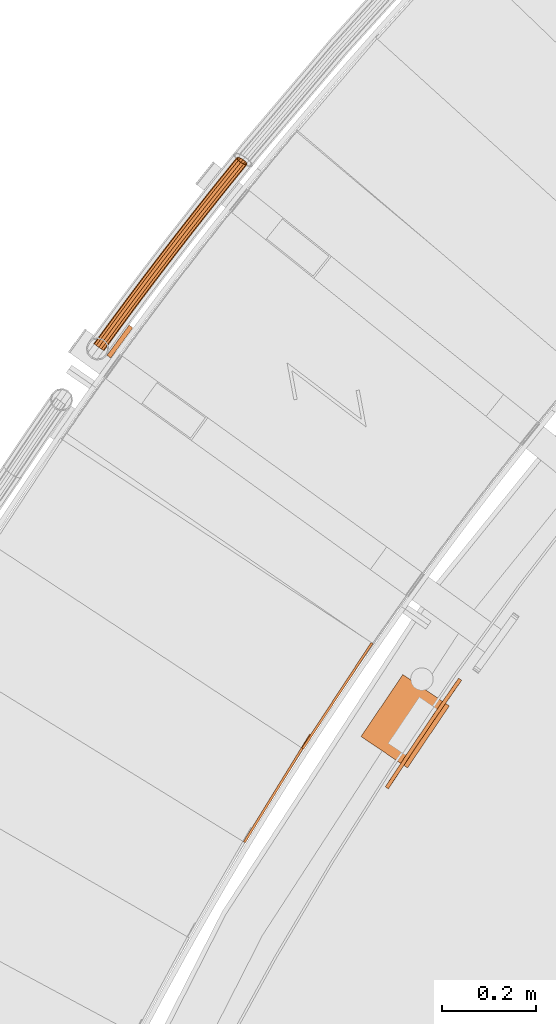
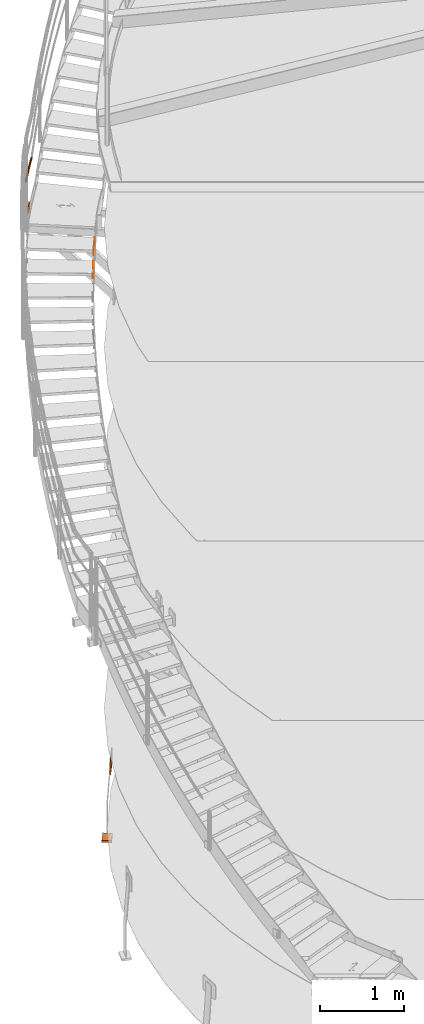
# One storey, part 67 of 126: 6 proxies.
"""IFC2X3 building model written with IfcOpenShell, lengths in millimetres."""

from ifc_helpers import new_model, si_unit, origin, origin_with_axes, place, context, project, spatial, faceted_brep, material, element, save


model = new_model("IFC2X3")

# Units and contexts
context_of_model_1 = context(None, 3, precision=0.1, world=origin())
context_of_model_2 = context(None, 3, precision=0.1, world=origin())
ifc_project = project(units=[si_unit("LENGTHUNIT", "METRE", prefix="MILLI"), si_unit("AREAUNIT", "SQUARE_METRE", prefix="CENTI"), si_unit("VOLUMEUNIT", "CUBIC_METRE", prefix="CENTI"), si_unit("MASSUNIT", "GRAM", prefix="KILO")], contexts=[context_of_model_1, context_of_model_2])

# Site, building, storey
site_placement = place(None, origin_with_axes())
site = spatial("IfcSite", under=ifc_project, at=site_placement, CompositionType="ELEMENT")
building_placement = place(site_placement, origin_with_axes())
building = spatial("IfcBuilding", under=site, at=building_placement, CompositionType="ELEMENT")
storey_placement = place(building_placement, origin_with_axes())
storey = spatial("IfcBuildingStorey", under=building, at=storey_placement, CompositionType="ELEMENT")

# Proxies
ifc_material_1 = material(Name="S235JRG2")
proxy_1_placement = place(storey_placement, origin_with_axes())
element("IfcBuildingElementProxy", 1, at=proxy_1_placement, inside=storey, material=ifc_material_1, context=context_of_model_2, shape_type="Brep", body=[
    faceted_brep([(1135.4304, 12147.675, 7896.89), (1139.6883, 12145.054, 7896.89), (1139.6883, 12145.054, 7966.89), (1135.4304, 12147.675, 7966.89), (1276.9731, 12377.6, 7966.89), (1281.231, 12374.979, 7966.89), (1281.231, 12374.979, 7926.89), (1276.9731, 12377.6, 7926.89), (1261.2462, 12352.053, 7896.89), (1265.504, 12349.432, 7896.89)], [[[0, 1, 2, 3]], [[4, 5, 6, 7]], [[0, 8, 9, 1]], [[1, 9, 6, 5, 2]], [[2, 5, 4, 3]], [[0, 3, 4, 7, 8]], [[6, 9, 8, 7]]]),
])
proxy_2_placement = place(storey_placement, origin_with_axes())
element("IfcBuildingElementProxy", 2, at=proxy_2_placement, inside=storey, material=ifc_material_1, context=context_of_model_2, shape_type="Brep", body=[
    faceted_brep([(1260.3402, 12348.075, 8070.05), (1264.5191, 12345.33, 8070.05), (1264.5191, 12345.33, 8140.05), (1260.3402, 12348.075, 8140.05), (1408.5891, 12573.735, 8140.05), (1412.768, 12570.99, 8140.05), (1412.768, 12570.99, 8100.05), (1408.5891, 12573.735, 8100.05), (1392.117, 12548.662, 8070.05), (1396.2959, 12545.916, 8070.05)], [[[0, 1, 2, 3]], [[4, 5, 6, 7]], [[0, 8, 9, 1]], [[1, 9, 6, 5, 2]], [[2, 5, 4, 3]], [[0, 3, 4, 7, 8]], [[6, 9, 8, 7]]]),
])
ifc_material_2 = material(Name="STAHL")
proxy_3_placement = place(storey_placement, origin_with_axes())
element("IfcBuildingElementProxy", 3, at=proxy_3_placement, inside=storey, material=ifc_material_2, Name="profile", context=context_of_model_2, shape_type="Brep", body=[
    faceted_brep([(1594.8, 12481.9, 704.7), (1597.2, 12485.4, 701.2), (1590.7, 12490.0, 701.2), (1588.0, 12486.1, 705.1), (1592.0, 12477.9, 707.5), (1584.8, 12481.6, 707.9), (1588.6, 12473.0, 709.4), (1581.7, 12477.1, 709.5), (1459.0, 12280.9, 709.5), (1462.0, 12285.5, 710.0), (1502.5, 12346.8, 710.0), (1543.5, 12407.6, 710.0), (1585.1, 12468.0, 710.0), (1578.6, 12472.6, 710.0), (1536.9, 12412.1, 710.0), (1495.8, 12351.2, 710.0), (1455.3, 12289.9, 710.0), (1452.0, 12284.8, 709.4), (1448.5, 12264.8, 697.0), (1450.4, 12267.8, 701.2), (1443.7, 12272.1, 701.2), (1441.6, 12268.9, 696.5), (1447.0, 12262.5, 692.0), (1440.1, 12266.5, 690.9), (1446.0, 12260.9, 686.0), (1439.2, 12265.2, 685.5), (1445.7, 12260.4, 680.0), (1438.9, 12264.8, 680.0), (1438.9, 12264.8, 520.0), (1439.3, 12265.3, 514.0), (1445.9, 12260.8, 514.5), (1445.7, 12260.4, 520.0), (1588.3, 12486.5, 495.3), (1590.7, 12490.0, 498.8), (1597.2, 12485.4, 498.8), (1594.5, 12481.6, 494.9), (1585.4, 12482.5, 492.5), (1591.4, 12477.0, 492.1), (1582.0, 12477.6, 490.6), (1588.2, 12472.5, 490.5), (1458.7, 12280.5, 490.6), (1452.3, 12285.3, 490.5), (1455.3, 12289.9, 490.0), (1495.8, 12351.2, 490.0), (1536.9, 12412.1, 490.0), (1578.6, 12472.6, 490.0), (1585.1, 12468.0, 490.0), (1543.5, 12407.6, 490.0), (1502.5, 12346.8, 490.0), (1462.0, 12285.5, 490.0), (1441.8, 12269.2, 503.0), (1443.7, 12272.1, 498.8), (1450.4, 12267.8, 498.8), (1448.3, 12264.6, 503.5), (1440.3, 12266.9, 508.0), (1446.8, 12262.1, 509.1), (1449.3, 12280.7, 492.1), (1455.5, 12275.5, 492.5), (1446.3, 12276.1, 494.9), (1452.8, 12271.3, 495.3), (1601.9, 12492.1, 514.0), (1595.4, 12496.8, 514.5), (1595.7, 12497.2, 520.0), (1595.7, 12497.2, 680.0), (1595.4, 12496.7, 686.0), (1602.0, 12492.2, 685.5), (1602.3, 12492.6, 680.0), (1602.3, 12492.6, 520.0), (1594.5, 12495.5, 509.1), (1600.8, 12490.6, 508.0), (1592.9, 12493.2, 503.5), (1599.3, 12488.3, 503.0), (1456.0, 12276.4, 707.9), (1448.8, 12279.8, 707.5), (1453.0, 12271.7, 705.1), (1446.0, 12275.7, 704.7), (1601.1, 12490.9, 690.9), (1594.3, 12495.2, 692.0), (1599.4, 12488.6, 696.5), (1592.7, 12492.9, 697.0)], [[[0, 1, 2, 3]], [[4, 0, 3, 5]], [[6, 4, 5, 7]], [[8, 9, 10, 11, 12, 6, 7, 13, 14, 15, 16, 17]], [[18, 19, 20, 21]], [[22, 18, 21, 23]], [[24, 22, 23, 25]], [[26, 24, 25, 27, 28, 29, 30, 31]], [[32, 33, 34, 35]], [[36, 32, 35, 37]], [[38, 36, 37, 39]], [[40, 41, 42, 43, 44, 45, 38, 39, 46, 47, 48, 49]], [[50, 51, 52, 53]], [[54, 50, 53, 55]], [[29, 54, 55, 30]], [[56, 41, 40, 57]], [[58, 56, 57, 59]], [[51, 58, 59, 52]], [[60, 61, 62, 63, 64, 65, 66, 67]], [[68, 61, 60, 69]], [[70, 68, 69, 71]], [[33, 70, 71, 34]], [[72, 8, 17, 73]], [[74, 72, 73, 75]], [[19, 74, 75, 20]], [[76, 65, 64, 77]], [[78, 76, 77, 79]], [[1, 78, 79, 2]], [[26, 31, 30, 55, 53, 52, 59, 57, 40, 49, 48, 47, 46, 39, 37, 35, 34, 71, 69, 60, 67, 66, 65, 76, 78, 1, 0, 4, 6, 12, 11, 10, 9, 8, 72, 74, 19, 18, 22, 24]], [[28, 27, 25, 23, 21, 20, 75, 73, 17, 16, 15, 14, 13, 7, 5, 3, 2, 79, 77, 64, 63, 62, 61, 68, 70, 33, 32, 36, 38, 45, 44, 43, 42, 41, 56, 58, 51, 50, 54, 29]]]),
])
proxy_4_placement = place(storey_placement, origin_with_axes())
element("IfcBuildingElementProxy", 4, at=proxy_4_placement, inside=storey, material=ifc_material_2, Name="profile", context=context_of_model_2, shape_type="Brep", body=[
    faceted_brep([(1486.5, 12305.3, -530.0), (1387.0, 12372.4, -530.0), (1476.5, 12505.0, -530.0), (1576.0, 12437.9, -530.0), (1387.0, 12372.4, -500.0), (1476.5, 12505.0, -500.0), (1486.5, 12305.3, -500.0), (1576.0, 12437.9, -500.0)], [[[0, 1, 2, 3]], [[1, 4, 5, 2]], [[4, 6, 7, 5]], [[6, 0, 3, 7]], [[1, 0, 6, 4]], [[7, 3, 2, 5]]]),
])
proxy_5_placement = place(storey_placement, origin_with_axes())
element("IfcBuildingElementProxy", 5, at=proxy_5_placement, inside=storey, material=ifc_material_1, context=context_of_model_2, shape_type="Brep", body=[
    faceted_brep([(822.0705, 13221.789, 8766.8551), (823.5285, 13220.73, 8760.1301), (816.714, 13211.312, 8760.1301), (815.2283, 13212.333, 8766.8551), (827.5119, 13217.837, 8755.207), (820.7729, 13208.524, 8755.207), (832.9532, 13213.885, 8753.4051), (826.3174, 13204.714, 8753.4051), (838.3945, 13209.933, 8755.207), (831.862, 13200.905, 8755.207), (842.3779, 13207.04, 8760.1301), (835.9209, 13198.117, 8760.1301), (843.8359, 13205.981, 8766.8551), (837.4066, 13197.096, 8766.8551), (842.3779, 13207.04, 8773.5801), (835.9209, 13198.117, 8773.5801), (838.3945, 13209.933, 8778.5031), (831.862, 13200.905, 8778.5031), (832.9532, 13213.885, 8780.3051), (826.3174, 13204.714, 8780.3051), (827.5119, 13217.837, 8778.5031), (820.7729, 13208.524, 8778.5031), (823.5285, 13220.73, 8773.5801), (816.714, 13211.312, 8773.5801), (823.6888, 13220.613, 8766.8551), (824.93, 13219.712, 8772.5801), (818.142, 13210.331, 8772.5801), (816.8772, 13211.2, 8766.8551), (828.321, 13217.249, 8776.7711), (821.5973, 13207.957, 8776.7711), (832.9532, 13213.885, 8778.3051), (826.3174, 13204.714, 8778.3051), (837.5854, 13210.521, 8776.7711), (831.0375, 13201.472, 8776.7711), (840.9764, 13208.058, 8772.5801), (834.4929, 13199.098, 8772.5801), (842.2176, 13207.156, 8766.8551), (835.7576, 13198.229, 8766.8551), (840.9764, 13208.058, 8761.1301), (834.4929, 13199.098, 8761.1301), (837.5854, 13210.521, 8756.9391), (831.0375, 13201.472, 8756.9391), (832.9532, 13213.885, 8755.4051), (826.3174, 13204.714, 8755.4051), (828.321, 13217.249, 8756.9391), (821.5973, 13207.957, 8756.9391), (824.93, 13219.712, 8761.1301), (818.142, 13210.331, 8761.1301), (840.3243, 13246.83, 8766.8551), (841.7786, 13245.766, 8760.1301), (845.7518, 13242.859, 8755.207), (851.1793, 13238.888, 8753.4051), (856.6068, 13234.917, 8755.207), (860.58, 13232.01, 8760.1301), (862.0343, 13230.946, 8766.8551), (860.58, 13232.01, 8773.5801), (856.6068, 13234.917, 8778.5031), (851.1793, 13238.888, 8780.3051), (845.7518, 13242.859, 8778.5031), (841.7786, 13245.766, 8773.5801), (841.9384, 13245.649, 8766.8551), (843.1765, 13244.743, 8772.5801), (846.5589, 13242.269, 8776.7711), (851.1793, 13238.888, 8778.3051), (855.7997, 13235.508, 8776.7711), (859.1821, 13233.033, 8772.5801), (860.4202, 13232.127, 8766.8551), (859.1821, 13233.033, 8761.1301), (855.7997, 13235.508, 8756.9391), (851.1793, 13238.888, 8755.4051), (846.5589, 13242.269, 8756.9391), (843.1765, 13244.743, 8761.1301), (858.6653, 13271.807, 8766.8551), (860.1159, 13270.738, 8760.1301), (864.079, 13267.817, 8755.207), (869.4926, 13263.828, 8753.4051), (874.9062, 13259.838, 8755.207), (878.8692, 13256.917, 8760.1301), (880.3198, 13255.848, 8766.8551), (878.8692, 13256.917, 8773.5801), (874.9062, 13259.838, 8778.5031), (869.4926, 13263.828, 8780.3051), (864.079, 13267.817, 8778.5031), (860.1159, 13270.738, 8773.5801), (860.2753, 13270.621, 8766.8551), (861.5102, 13269.711, 8772.5801), (864.8839, 13267.224, 8776.7711), (869.4926, 13263.828, 8778.3051), (874.1012, 13260.431, 8776.7711), (877.4749, 13257.945, 8772.5801), (878.7098, 13257.035, 8766.8551), (877.4749, 13257.945, 8761.1301), (874.1012, 13260.431, 8756.9391), (869.4926, 13263.828, 8755.4051), (864.8839, 13267.224, 8756.9391), (861.5102, 13269.711, 8761.1301), (877.0935, 13296.721, 8766.8551), (878.5403, 13295.647, 8760.1301), (882.4931, 13292.712, 8755.207), (887.8928, 13288.703, 8753.4051), (893.2924, 13284.695, 8755.207), (897.2453, 13281.76, 8760.1301), (898.6921, 13280.686, 8766.8551), (897.2453, 13281.76, 8773.5801), (893.2924, 13284.695, 8778.5031), (887.8928, 13288.703, 8780.3051), (882.4931, 13292.712, 8778.5031), (878.5403, 13295.647, 8773.5801), (878.6993, 13295.528, 8766.8551), (879.931, 13294.614, 8772.5801), (883.296, 13292.116, 8776.7711), (887.8928, 13288.703, 8778.3051), (892.4895, 13285.291, 8776.7711), (895.8545, 13282.793, 8772.5801), (897.0862, 13281.878, 8766.8551), (895.8545, 13282.793, 8761.1301), (892.4895, 13285.291, 8756.9391), (887.8928, 13288.703, 8755.4051), (883.296, 13292.116, 8756.9391), (879.931, 13294.614, 8761.1301), (895.6084, 13321.569, 8766.8551), (897.0515, 13320.49, 8760.1301), (900.9941, 13317.542, 8755.207), (906.3797, 13313.514, 8753.4051), (911.7653, 13309.487, 8755.207), (915.7079, 13306.539, 8760.1301), (917.151, 13305.459, 8766.8551), (915.7079, 13306.539, 8773.5801), (911.7653, 13309.487, 8778.5031), (906.3797, 13313.514, 8780.3051), (900.9941, 13317.542, 8778.5031), (897.0515, 13320.49, 8773.5801), (897.2101, 13320.372, 8766.8551), (898.4386, 13319.453, 8772.5801), (901.7949, 13316.943, 8776.7711), (906.3797, 13313.514, 8778.3051), (910.9645, 13310.086, 8776.7711), (914.3208, 13307.576, 8772.5801), (915.5493, 13306.657, 8766.8551), (914.3208, 13307.576, 8761.1301), (910.9645, 13310.086, 8756.9391), (906.3797, 13313.514, 8755.4051), (901.7949, 13316.943, 8756.9391), (898.4386, 13319.453, 8761.1301), (914.21, 13346.353, 8766.8551), (915.6493, 13345.269, 8760.1301), (919.5816, 13342.307, 8755.207), (924.9531, 13338.261, 8753.4051), (930.3247, 13334.215, 8755.207), (934.2569, 13331.253, 8760.1301), (935.6962, 13330.168, 8766.8551), (934.2569, 13331.253, 8773.5801), (930.3247, 13334.215, 8778.5031), (924.9531, 13338.261, 8780.3051), (919.5816, 13342.307, 8778.5031), (915.6493, 13345.269, 8773.5801), (915.8075, 13345.15, 8766.8551), (917.0328, 13344.227, 8772.5801), (920.3803, 13341.706, 8776.7711), (924.9531, 13338.261, 8778.3051), (929.5259, 13334.816, 8776.7711), (932.8734, 13332.295, 8772.5801), (934.0987, 13331.372, 8766.8551), (932.8734, 13332.295, 8761.1301), (929.5259, 13334.816, 8756.9391), (924.9531, 13338.261, 8755.4051), (920.3803, 13341.706, 8756.9391), (917.0328, 13344.227, 8761.1301), (932.898, 13371.072, 8766.8551), (934.3336, 13369.983, 8760.1301), (938.2554, 13367.007, 8755.207), (943.6128, 13362.942, 8753.4051), (948.9702, 13358.877, 8755.207), (952.8921, 13355.902, 8760.1301), (954.3276, 13354.812, 8766.8551), (952.8921, 13355.902, 8773.5801), (948.9702, 13358.877, 8778.5031), (943.6128, 13362.942, 8780.3051), (938.2554, 13367.007, 8778.5031), (934.3336, 13369.983, 8773.5801), (934.4913, 13369.863, 8766.8551), (935.7134, 13368.936, 8772.5801), (939.0521, 13366.403, 8776.7711), (943.6128, 13362.942, 8778.3051), (948.1736, 13359.482, 8776.7711), (951.5122, 13356.949, 8772.5801), (952.7343, 13356.021, 8766.8551), (951.5122, 13356.949, 8761.1301), (948.1736, 13359.482, 8756.9391), (943.6128, 13362.942, 8755.4051), (939.0521, 13366.403, 8756.9391), (935.7134, 13368.936, 8761.1301), (951.6722, 13395.726, 8766.8551), (953.1039, 13394.632, 8760.1301), (957.0154, 13391.642, 8755.207), (962.3585, 13387.559, 8753.4051), (967.7017, 13383.475, 8755.207), (971.6132, 13380.485, 8760.1301), (973.0449, 13379.391, 8766.8551), (971.6132, 13380.485, 8773.5801), (967.7017, 13383.475, 8778.5031), (962.3585, 13387.559, 8780.3051), (957.0154, 13391.642, 8778.5031), (953.1039, 13394.632, 8773.5801), (953.2613, 13394.511, 8766.8551), (954.4801, 13393.58, 8772.5801), (957.8099, 13391.035, 8776.7711), (962.3585, 13387.559, 8778.3051), (966.9072, 13384.082, 8776.7711), (970.237, 13381.537, 8772.5801), (971.4558, 13380.606, 8766.8551), (970.237, 13381.537, 8761.1301), (966.9072, 13384.082, 8756.9391), (962.3585, 13387.559, 8755.4051), (957.8099, 13391.035, 8756.9391), (954.4801, 13393.58, 8761.1301), (970.5323, 13420.314, 8766.8551), (971.9602, 13419.215, 8760.1301), (975.8612, 13416.211, 8755.207), (981.1901, 13412.109, 8753.4051), (986.519, 13408.007, 8755.207), (990.42, 13405.004, 8760.1301), (991.8478, 13403.905, 8766.8551), (990.42, 13405.004, 8773.5801), (986.519, 13408.007, 8778.5031), (981.1901, 13412.109, 8780.3051), (975.8612, 13416.211, 8778.5031), (971.9602, 13419.215, 8773.5801), (972.1171, 13419.094, 8766.8551), (973.3327, 13418.158, 8772.5801), (976.6536, 13415.602, 8776.7711), (981.1901, 13412.109, 8778.3051), (985.7266, 13408.617, 8776.7711), (989.0475, 13406.06, 8772.5801), (990.263, 13405.125, 8766.8551), (989.0475, 13406.06, 8761.1301), (985.7266, 13408.617, 8756.9391), (981.1901, 13412.109, 8755.4051), (976.6536, 13415.602, 8756.9391), (973.3327, 13418.158, 8761.1301), (989.4782, 13444.836, 8766.8551), (990.9022, 13443.732, 8760.1301), (994.7927, 13440.715, 8755.207), (1000.1072, 13436.594, 8753.4051), (1005.4217, 13432.473, 8755.207), (1009.3122, 13429.456, 8760.1301), (1010.7362, 13428.352, 8766.8551), (1009.3122, 13429.456, 8773.5801), (1005.4217, 13432.473, 8778.5031), (1000.1072, 13436.594, 8780.3051), (994.7927, 13440.715, 8778.5031), (990.9022, 13443.732, 8773.5801), (991.0587, 13443.61, 8766.8551), (992.271, 13442.67, 8772.5801), (995.5829, 13440.102, 8776.7711), (1000.1072, 13436.594, 8778.3051), (1004.6315, 13433.086, 8776.7711), (1007.9434, 13430.518, 8772.5801), (1009.1557, 13429.578, 8766.8551), (1007.9434, 13430.518, 8761.1301), (1004.6315, 13433.086, 8756.9391), (1000.1072, 13436.594, 8755.4051), (995.5829, 13440.102, 8756.9391), (992.271, 13442.67, 8761.1301), (1008.5095, 13469.291, 8766.8551), (1009.9296, 13468.182, 8760.1301), (1013.8096, 13465.152, 8755.207), (1019.1097, 13461.012, 8753.4051), (1024.4098, 13456.873, 8755.207), (1028.2897, 13453.843, 8760.1301), (1029.7099, 13452.734, 8766.8551), (1028.2897, 13453.843, 8773.5801), (1024.4098, 13456.873, 8778.5031), (1019.1097, 13461.012, 8780.3051), (1013.8096, 13465.152, 8778.5031), (1009.9296, 13468.182, 8773.5801), (1010.0857, 13468.06, 8766.8551), (1011.2947, 13467.116, 8772.5801), (1014.5977, 13464.536, 8776.7711), (1019.1097, 13461.012, 8778.3051), (1023.6217, 13457.489, 8776.7711), (1026.9247, 13454.909, 8772.5801), (1028.1336, 13453.965, 8766.8551), (1026.9247, 13454.909, 8761.1301), (1023.6217, 13457.489, 8756.9391), (1019.1097, 13461.012, 8755.4051), (1014.5977, 13464.536, 8756.9391), (1011.2947, 13467.116, 8761.1301), (1027.626, 13493.68, 8766.8551), (1029.0423, 13492.566, 8760.1301), (1032.9117, 13489.522, 8755.207), (1038.1973, 13485.365, 8753.4051), (1043.4829, 13481.207, 8755.207), (1047.3522, 13478.163, 8760.1301), (1048.7685, 13477.049, 8766.8551), (1047.3522, 13478.163, 8773.5801), (1043.4829, 13481.207, 8778.5031), (1038.1973, 13485.365, 8780.3051), (1032.9117, 13489.522, 8778.5031), (1029.0423, 13492.566, 8773.5801), (1029.198, 13492.444, 8766.8551), (1030.4036, 13491.495, 8772.5801), (1033.6976, 13488.904, 8776.7711), (1038.1973, 13485.365, 8778.3051), (1042.6969, 13481.825, 8776.7711), (1045.9909, 13479.234, 8772.5801), (1047.1966, 13478.285, 8766.8551), (1045.9909, 13479.234, 8761.1301), (1042.6969, 13481.825, 8756.9391), (1038.1973, 13485.365, 8755.4051), (1033.6976, 13488.904, 8756.9391), (1030.4036, 13491.495, 8761.1301), (1046.8276, 13518.002, 8766.8551), (1048.24, 13516.883, 8760.1301), (1052.0987, 13513.826, 8755.207), (1057.3698, 13509.65, 8753.4051), (1062.6408, 13505.474, 8755.207), (1066.4995, 13502.416, 8760.1301), (1067.9119, 13501.297, 8766.8551), (1066.4995, 13502.416, 8773.5801), (1062.6408, 13505.474, 8778.5031), (1057.3698, 13509.65, 8780.3051), (1052.0987, 13513.826, 8778.5031), (1048.24, 13516.883, 8773.5801), (1048.3952, 13516.76, 8766.8551), (1049.5976, 13515.808, 8772.5801), (1052.8825, 13513.205, 8776.7711), (1057.3698, 13509.65, 8778.3051), (1061.857, 13506.094, 8776.7711), (1065.1419, 13503.492, 8772.5801), (1066.3443, 13502.539, 8766.8551), (1065.1419, 13503.492, 8761.1301), (1061.857, 13506.094, 8756.9391), (1057.3698, 13509.65, 8755.4051), (1052.8825, 13513.205, 8756.9391), (1049.5976, 13515.808, 8761.1301), (1066.114, 13542.257, 8766.8551), (1067.5224, 13541.133, 8760.1301), (1071.3704, 13538.063, 8755.207), (1076.6269, 13533.868, 8753.4051), (1081.8834, 13529.673, 8755.207), (1085.7314, 13526.603, 8760.1301), (1087.1398, 13525.479, 8766.8551), (1085.7314, 13526.603, 8773.5801), (1081.8834, 13529.673, 8778.5031), (1076.6269, 13533.868, 8780.3051), (1071.3704, 13538.063, 8778.5031), (1067.5224, 13541.133, 8773.5801), (1067.6772, 13541.01, 8766.8551), (1068.8763, 13540.053, 8772.5801), (1072.1521, 13537.439, 8776.7711), (1076.6269, 13533.868, 8778.3051), (1081.1017, 13530.297, 8776.7711), (1084.3775, 13527.683, 8772.5801), (1085.5766, 13526.726, 8766.8551), (1084.3775, 13527.683, 8761.1301), (1081.1017, 13530.297, 8756.9391), (1076.6269, 13533.868, 8755.4051), (1072.1521, 13537.439, 8756.9391), (1068.8763, 13540.053, 8761.1301), (1085.4849, 13566.445, 8766.8551), (1086.8894, 13565.316, 8760.1301), (1090.7267, 13562.232, 8755.207), (1095.9685, 13558.019, 8753.4051), (1101.2103, 13553.806, 8755.207), (1105.0475, 13550.722, 8760.1301), (1106.452, 13549.593, 8766.8551), (1105.0475, 13550.722, 8773.5801), (1101.2103, 13553.806, 8778.5031), (1095.9685, 13558.019, 8780.3051), (1090.7267, 13562.232, 8778.5031), (1086.8894, 13565.316, 8773.5801), (1087.0438, 13565.192, 8766.8551), (1088.2395, 13564.231, 8772.5801), (1091.5061, 13561.605, 8776.7711), (1095.9685, 13558.019, 8778.3051), (1100.4308, 13554.432, 8776.7711), (1103.6975, 13551.807, 8772.5801), (1104.8932, 13550.846, 8766.8551), (1103.6975, 13551.807, 8761.1301), (1100.4308, 13554.432, 8756.9391), (1095.9685, 13558.019, 8755.4051), (1091.5061, 13561.605, 8756.9391), (1088.2395, 13564.231, 8761.1301), (1104.9401, 13590.565, 8766.8551), (1106.3407, 13589.431, 8760.1301), (1110.1672, 13586.333, 8755.207), (1115.3942, 13582.102, 8753.4051), (1120.6213, 13577.871, 8755.207), (1124.4477, 13574.773, 8760.1301), (1125.8483, 13573.639, 8766.8551), (1124.4477, 13574.773, 8773.5801), (1120.6213, 13577.871, 8778.5031), (1115.3942, 13582.102, 8780.3051), (1110.1672, 13586.333, 8778.5031), (1106.3407, 13589.431, 8773.5801), (1106.4946, 13589.306, 8766.8551), (1107.6869, 13588.341, 8772.5801), (1110.9444, 13585.704, 8776.7711), (1115.3942, 13582.102, 8778.3051), (1119.844, 13578.5, 8776.7711), (1123.1015, 13575.863, 8772.5801), (1124.2938, 13574.898, 8766.8551), (1123.1015, 13575.863, 8761.1301), (1119.844, 13578.5, 8756.9391), (1115.3942, 13582.102, 8755.4051), (1110.9444, 13585.704, 8756.9391), (1107.6869, 13588.341, 8761.1301), (1121.3614, 13610.778, 8766.8551), (1124.197, 13611.411, 8760.1301), (1129.2528, 13609.827, 8755.207), (1132.9176, 13607.737, 8754.0918), (1134.9039, 13606.117, 8753.4051), (1140.1162, 13601.868, 8755.207), (1141.4664, 13600.767, 8756.9492), (1143.4602, 13598.177, 8760.1301), (1143.6047, 13595.496, 8766.8551), (1140.7691, 13594.864, 8773.5801), (1135.7133, 13596.448, 8778.5031), (1129.792, 13599.825, 8780.3051), (1124.5917, 13604.089, 8778.5031), (1121.5059, 13608.098, 8773.5801), (1123.0152, 13609.642, 8766.8551), (1123.1382, 13607.361, 8772.5801), (1125.7651, 13603.948, 8776.7711), (1130.1921, 13600.317, 8778.3051), (1135.233, 13597.443, 8776.7711), (1139.537, 13596.094, 8772.5801), (1141.9509, 13596.633, 8766.8551), (1141.8279, 13598.914, 8761.1301), (1139.201, 13602.327, 8756.9391), (1134.774, 13605.957, 8755.4051), (1129.7331, 13608.832, 8756.9391), (1125.4291, 13610.181, 8761.1301), (1135.1754, 13606.449, 8753.4051), (1140.3756, 13602.185, 8755.207)], [[[0, 1, 2, 3]], [[1, 4, 5, 2]], [[4, 6, 7, 5]], [[6, 8, 9, 7]], [[8, 10, 11, 9]], [[10, 12, 13, 11]], [[12, 14, 15, 13]], [[14, 16, 17, 15]], [[16, 18, 19, 17]], [[18, 20, 21, 19]], [[20, 22, 23, 21]], [[0, 3, 23, 22]], [[24, 25, 26, 27]], [[25, 28, 29, 26]], [[28, 30, 31, 29]], [[30, 32, 33, 31]], [[32, 34, 35, 33]], [[34, 36, 37, 35]], [[36, 38, 39, 37]], [[38, 40, 41, 39]], [[40, 42, 43, 41]], [[42, 44, 45, 43]], [[44, 46, 47, 45]], [[24, 27, 47, 46]], [[0, 48, 49, 1]], [[1, 49, 50, 4]], [[4, 50, 51, 6]], [[6, 51, 52, 8]], [[8, 52, 53, 10]], [[10, 53, 54, 12]], [[12, 54, 55, 14]], [[14, 55, 56, 16]], [[16, 56, 57, 18]], [[18, 57, 58, 20]], [[20, 58, 59, 22]], [[22, 59, 48, 0]], [[24, 60, 61, 25]], [[25, 61, 62, 28]], [[28, 62, 63, 30]], [[30, 63, 64, 32]], [[32, 64, 65, 34]], [[34, 65, 66, 36]], [[36, 66, 67, 38]], [[38, 67, 68, 40]], [[40, 68, 69, 42]], [[42, 69, 70, 44]], [[44, 70, 71, 46]], [[46, 71, 60, 24]], [[48, 72, 73, 49]], [[49, 73, 74, 50]], [[50, 74, 75, 51]], [[51, 75, 76, 52]], [[52, 76, 77, 53]], [[53, 77, 78, 54]], [[54, 78, 79, 55]], [[55, 79, 80, 56]], [[56, 80, 81, 57]], [[57, 81, 82, 58]], [[58, 82, 83, 59]], [[59, 83, 72, 48]], [[60, 84, 85, 61]], [[61, 85, 86, 62]], [[62, 86, 87, 63]], [[63, 87, 88, 64]], [[64, 88, 89, 65]], [[65, 89, 90, 66]], [[66, 90, 91, 67]], [[67, 91, 92, 68]], [[68, 92, 93, 69]], [[69, 93, 94, 70]], [[70, 94, 95, 71]], [[71, 95, 84, 60]], [[72, 96, 97, 73]], [[73, 97, 98, 74]], [[74, 98, 99, 75]], [[75, 99, 100, 76]], [[76, 100, 101, 77]], [[77, 101, 102, 78]], [[78, 102, 103, 79]], [[79, 103, 104, 80]], [[80, 104, 105, 81]], [[81, 105, 106, 82]], [[82, 106, 107, 83]], [[83, 107, 96, 72]], [[84, 108, 109, 85]], [[85, 109, 110, 86]], [[86, 110, 111, 87]], [[87, 111, 112, 88]], [[88, 112, 113, 89]], [[89, 113, 114, 90]], [[90, 114, 115, 91]], [[91, 115, 116, 92]], [[92, 116, 117, 93]], [[93, 117, 118, 94]], [[94, 118, 119, 95]], [[95, 119, 108, 84]], [[96, 120, 121, 97]], [[97, 121, 122, 98]], [[98, 122, 123, 99]], [[99, 123, 124, 100]], [[100, 124, 125, 101]], [[101, 125, 126, 102]], [[102, 126, 127, 103]], [[103, 127, 128, 104]], [[104, 128, 129, 105]], [[105, 129, 130, 106]], [[106, 130, 131, 107]], [[107, 131, 120, 96]], [[108, 132, 133, 109]], [[109, 133, 134, 110]], [[110, 134, 135, 111]], [[111, 135, 136, 112]], [[112, 136, 137, 113]], [[113, 137, 138, 114]], [[114, 138, 139, 115]], [[115, 139, 140, 116]], [[116, 140, 141, 117]], [[117, 141, 142, 118]], [[118, 142, 143, 119]], [[119, 143, 132, 108]], [[120, 144, 145, 121]], [[121, 145, 146, 122]], [[122, 146, 147, 123]], [[123, 147, 148, 124]], [[124, 148, 149, 125]], [[125, 149, 150, 126]], [[126, 150, 151, 127]], [[127, 151, 152, 128]], [[128, 152, 153, 129]], [[129, 153, 154, 130]], [[130, 154, 155, 131]], [[131, 155, 144, 120]], [[132, 156, 157, 133]], [[133, 157, 158, 134]], [[134, 158, 159, 135]], [[135, 159, 160, 136]], [[136, 160, 161, 137]], [[137, 161, 162, 138]], [[138, 162, 163, 139]], [[139, 163, 164, 140]], [[140, 164, 165, 141]], [[141, 165, 166, 142]], [[142, 166, 167, 143]], [[143, 167, 156, 132]], [[144, 168, 169, 145]], [[145, 169, 170, 146]], [[146, 170, 171, 147]], [[147, 171, 172, 148]], [[148, 172, 173, 149]], [[149, 173, 174, 150]], [[150, 174, 175, 151]], [[151, 175, 176, 152]], [[152, 176, 177, 153]], [[153, 177, 178, 154]], [[154, 178, 179, 155]], [[155, 179, 168, 144]], [[156, 180, 181, 157]], [[157, 181, 182, 158]], [[158, 182, 183, 159]], [[159, 183, 184, 160]], [[160, 184, 185, 161]], [[161, 185, 186, 162]], [[162, 186, 187, 163]], [[163, 187, 188, 164]], [[164, 188, 189, 165]], [[165, 189, 190, 166]], [[166, 190, 191, 167]], [[167, 191, 180, 156]], [[168, 192, 193, 169]], [[169, 193, 194, 170]], [[170, 194, 195, 171]], [[171, 195, 196, 172]], [[172, 196, 197, 173]], [[173, 197, 198, 174]], [[174, 198, 199, 175]], [[175, 199, 200, 176]], [[176, 200, 201, 177]], [[177, 201, 202, 178]], [[178, 202, 203, 179]], [[179, 203, 192, 168]], [[180, 204, 205, 181]], [[181, 205, 206, 182]], [[182, 206, 207, 183]], [[183, 207, 208, 184]], [[184, 208, 209, 185]], [[185, 209, 210, 186]], [[186, 210, 211, 187]], [[187, 211, 212, 188]], [[188, 212, 213, 189]], [[189, 213, 214, 190]], [[190, 214, 215, 191]], [[191, 215, 204, 180]], [[192, 216, 217, 193]], [[193, 217, 218, 194]], [[194, 218, 219, 195]], [[195, 219, 220, 196]], [[196, 220, 221, 197]], [[197, 221, 222, 198]], [[198, 222, 223, 199]], [[199, 223, 224, 200]], [[200, 224, 225, 201]], [[201, 225, 226, 202]], [[202, 226, 227, 203]], [[203, 227, 216, 192]], [[204, 228, 229, 205]], [[205, 229, 230, 206]], [[206, 230, 231, 207]], [[207, 231, 232, 208]], [[208, 232, 233, 209]], [[209, 233, 234, 210]], [[210, 234, 235, 211]], [[211, 235, 236, 212]], [[212, 236, 237, 213]], [[213, 237, 238, 214]], [[214, 238, 239, 215]], [[215, 239, 228, 204]], [[216, 240, 241, 217]], [[217, 241, 242, 218]], [[218, 242, 243, 219]], [[219, 243, 244, 220]], [[220, 244, 245, 221]], [[221, 245, 246, 222]], [[222, 246, 247, 223]], [[223, 247, 248, 224]], [[224, 248, 249, 225]], [[225, 249, 250, 226]], [[226, 250, 251, 227]], [[227, 251, 240, 216]], [[228, 252, 253, 229]], [[229, 253, 254, 230]], [[230, 254, 255, 231]], [[231, 255, 256, 232]], [[232, 256, 257, 233]], [[233, 257, 258, 234]], [[234, 258, 259, 235]], [[235, 259, 260, 236]], [[236, 260, 261, 237]], [[237, 261, 262, 238]], [[238, 262, 263, 239]], [[239, 263, 252, 228]], [[240, 264, 265, 241]], [[241, 265, 266, 242]], [[242, 266, 267, 243]], [[243, 267, 268, 244]], [[244, 268, 269, 245]], [[245, 269, 270, 246]], [[246, 270, 271, 247]], [[247, 271, 272, 248]], [[248, 272, 273, 249]], [[249, 273, 274, 250]], [[250, 274, 275, 251]], [[251, 275, 264, 240]], [[252, 276, 277, 253]], [[253, 277, 278, 254]], [[254, 278, 279, 255]], [[255, 279, 280, 256]], [[256, 280, 281, 257]], [[257, 281, 282, 258]], [[258, 282, 283, 259]], [[259, 283, 284, 260]], [[260, 284, 285, 261]], [[261, 285, 286, 262]], [[262, 286, 287, 263]], [[263, 287, 276, 252]], [[264, 288, 289, 265]], [[265, 289, 290, 266]], [[266, 290, 291, 267]], [[267, 291, 292, 268]], [[268, 292, 293, 269]], [[269, 293, 294, 270]], [[270, 294, 295, 271]], [[271, 295, 296, 272]], [[272, 296, 297, 273]], [[273, 297, 298, 274]], [[274, 298, 299, 275]], [[275, 299, 288, 264]], [[276, 300, 301, 277]], [[277, 301, 302, 278]], [[278, 302, 303, 279]], [[279, 303, 304, 280]], [[280, 304, 305, 281]], [[281, 305, 306, 282]], [[282, 306, 307, 283]], [[283, 307, 308, 284]], [[284, 308, 309, 285]], [[285, 309, 310, 286]], [[286, 310, 311, 287]], [[287, 311, 300, 276]], [[288, 312, 313, 289]], [[289, 313, 314, 290]], [[290, 314, 315, 291]], [[291, 315, 316, 292]], [[292, 316, 317, 293]], [[293, 317, 318, 294]], [[294, 318, 319, 295]], [[295, 319, 320, 296]], [[296, 320, 321, 297]], [[297, 321, 322, 298]], [[298, 322, 323, 299]], [[299, 323, 312, 288]], [[300, 324, 325, 301]], [[301, 325, 326, 302]], [[302, 326, 327, 303]], [[303, 327, 328, 304]], [[304, 328, 329, 305]], [[305, 329, 330, 306]], [[306, 330, 331, 307]], [[307, 331, 332, 308]], [[308, 332, 333, 309]], [[309, 333, 334, 310]], [[310, 334, 335, 311]], [[311, 335, 324, 300]], [[312, 336, 337, 313]], [[313, 337, 338, 314]], [[314, 338, 339, 315]], [[315, 339, 340, 316]], [[316, 340, 341, 317]], [[317, 341, 342, 318]], [[318, 342, 343, 319]], [[319, 343, 344, 320]], [[320, 344, 345, 321]], [[321, 345, 346, 322]], [[322, 346, 347, 323]], [[323, 347, 336, 312]], [[324, 348, 349, 325]], [[325, 349, 350, 326]], [[326, 350, 351, 327]], [[327, 351, 352, 328]], [[328, 352, 353, 329]], [[329, 353, 354, 330]], [[330, 354, 355, 331]], [[331, 355, 356, 332]], [[332, 356, 357, 333]], [[333, 357, 358, 334]], [[334, 358, 359, 335]], [[335, 359, 348, 324]], [[336, 360, 361, 337]], [[337, 361, 362, 338]], [[338, 362, 363, 339]], [[339, 363, 364, 340]], [[340, 364, 365, 341]], [[341, 365, 366, 342]], [[342, 366, 367, 343]], [[343, 367, 368, 344]], [[344, 368, 369, 345]], [[345, 369, 370, 346]], [[346, 370, 371, 347]], [[347, 371, 360, 336]], [[348, 372, 373, 349]], [[349, 373, 374, 350]], [[350, 374, 375, 351]], [[351, 375, 376, 352]], [[352, 376, 377, 353]], [[353, 377, 378, 354]], [[354, 378, 379, 355]], [[355, 379, 380, 356]], [[356, 380, 381, 357]], [[357, 381, 382, 358]], [[358, 382, 383, 359]], [[359, 383, 372, 348]], [[360, 384, 385, 361]], [[361, 385, 386, 362]], [[362, 386, 387, 363]], [[363, 387, 388, 364]], [[364, 388, 389, 365]], [[365, 389, 390, 366]], [[366, 390, 391, 367]], [[367, 391, 392, 368]], [[368, 392, 393, 369]], [[369, 393, 394, 370]], [[370, 394, 395, 371]], [[371, 395, 384, 360]], [[372, 396, 397, 373]], [[373, 397, 398, 374]], [[374, 398, 399, 375]], [[375, 399, 400, 376]], [[376, 400, 401, 377]], [[377, 401, 402, 378]], [[378, 402, 403, 379]], [[379, 403, 404, 380]], [[380, 404, 405, 381]], [[381, 405, 406, 382]], [[382, 406, 407, 383]], [[383, 407, 396, 372]], [[384, 408, 409, 385]], [[385, 409, 410, 386]], [[386, 410, 411, 412, 387]], [[387, 412, 413, 388]], [[388, 413, 414, 415, 389]], [[389, 415, 416, 390]], [[390, 416, 417, 391]], [[391, 417, 418, 392]], [[392, 418, 419, 393]], [[393, 419, 420, 394]], [[394, 420, 421, 395]], [[384, 395, 421, 408]], [[396, 422, 423, 397]], [[397, 423, 424, 398]], [[398, 424, 425, 399]], [[399, 425, 426, 400]], [[400, 426, 427, 401]], [[401, 427, 428, 402]], [[402, 428, 429, 403]], [[403, 429, 430, 404]], [[404, 430, 431, 405]], [[405, 431, 432, 406]], [[406, 432, 433, 407]], [[396, 407, 433, 422]], [[411, 434, 412]], [[412, 434, 435, 413]], [[413, 435, 414]], [[7, 9, 11, 13, 15, 17, 19, 21, 23, 3, 2, 5], [26, 29, 31, 33, 35, 37, 39, 41, 43, 45, 47, 27]], [[408, 421, 420, 419, 418, 417, 416, 415, 414, 435, 434, 411, 410, 409], [422, 433, 432, 431, 430, 429, 428, 427, 426, 425, 424, 423]]]),
])
proxy_6_placement = place(storey_placement, origin_with_axes())
element("IfcBuildingElementProxy", 6, at=proxy_6_placement, inside=storey, material=ifc_material_1, Name="HANDLAUF", context=context_of_model_2, shape_type="Brep", body=[
    faceted_brep([(851.8578, 13181.769, 8313.85), (843.7889, 13187.676, 8313.85), (891.0453, 13252.227, 8313.85), (899.1142, 13246.32, 8313.85), (851.8578, 13181.769, 8413.85), (899.1142, 13246.32, 8413.85), (891.0453, 13252.227, 8413.85), (843.7889, 13187.676, 8413.85)], [[[0, 1, 2, 3]], [[4, 5, 6, 7]], [[0, 4, 7, 1]], [[1, 7, 6, 2]], [[2, 6, 5, 3]], [[3, 5, 4, 0]]]),
])

save(model, "model.ifc")
